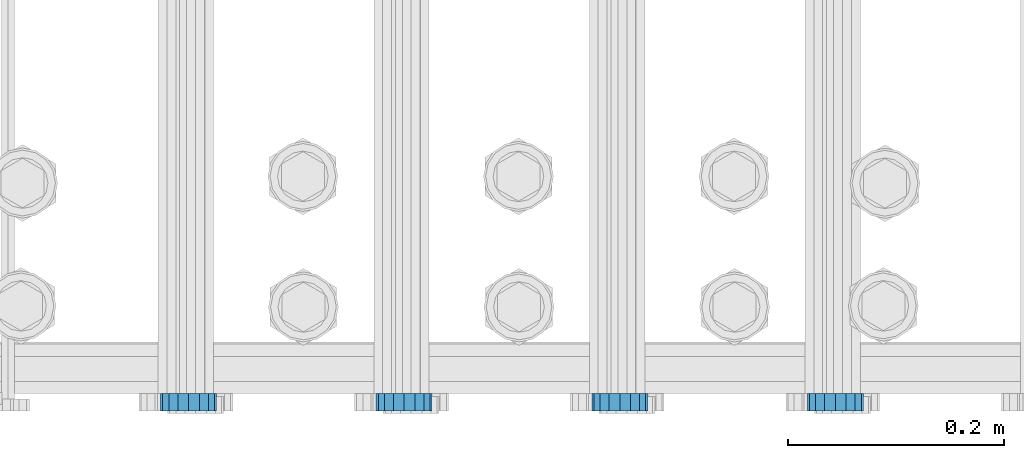
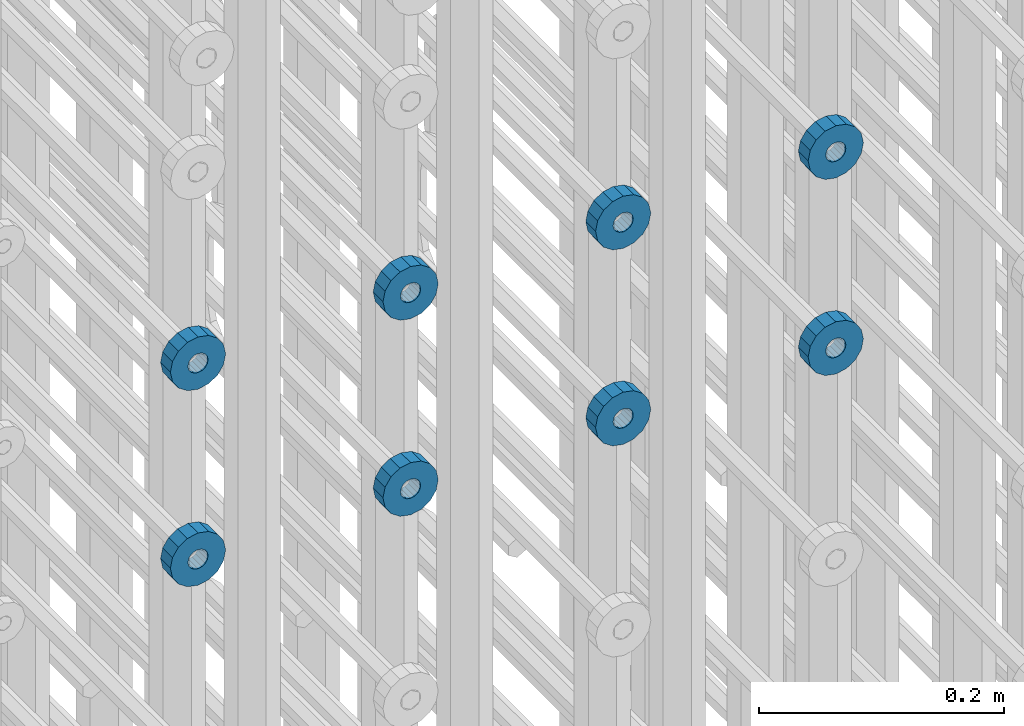
# One storey, part 131 of 177: 8 beams.
"""IFC2X3 building model written with IfcOpenShell, lengths in millimetres."""

from ifc_helpers import new_model, si_unit, frame, origin_with_axes, place, context, subcontext, project, spatial, faceted_brep, material, type_object, element, save


model = new_model("IFC2X3")

# Units and contexts
model_context_1 = context("Model", 3, precision=1e-05, world=origin_with_axes())
model_context_2 = context("Model", 3, precision=1e-05, world=origin_with_axes())
body_context = subcontext(model_context_2, "Body", "Model", "MODEL_VIEW")
ifc_project = project(units=[si_unit("LENGTHUNIT", "METRE", prefix="MILLI"), si_unit("AREAUNIT", "SQUARE_METRE"), si_unit("VOLUMEUNIT", "CUBIC_METRE"), si_unit("MASSUNIT", "GRAM", prefix="KILO"), si_unit("TIMEUNIT", "SECOND"), si_unit("PLANEANGLEUNIT", "RADIAN"), si_unit("SOLIDANGLEUNIT", "STERADIAN"), si_unit("THERMODYNAMICTEMPERATUREUNIT", "DEGREE_CELSIUS"), si_unit("LUMINOUSINTENSITYUNIT", "LUMEN")], contexts=[model_context_1])

# Site, building, storey
site_placement = place(None, origin_with_axes())
site = spatial("IfcSite", under=ifc_project, at=site_placement, CompositionType="ELEMENT")
building_placement = place(site_placement, origin_with_axes())
building = spatial("IfcBuilding", under=site, at=building_placement, Name="Undefined", CompositionType="ELEMENT")
storey_placement = place(building_placement, origin_with_axes())
storey = spatial("IfcBuildingStorey", under=building, at=storey_placement, Name="Undefined", CompositionType="ELEMENT", Elevation=0.0)

# Beams
ifc_material = material(Name="STEEL/Steel_Undefined")
beam_type = type_object("IfcBeamType", PredefinedType="NOTDEFINED")
beam_1_placement = place(storey_placement, frame((2032729.49847313, 6205075.98588032, 21954.9868114201), z_axis=(0.0, 0.0, -1.0), x_axis=(0.0, -1.0, 0.0)))
element("IfcBeam", 1, at=beam_1_placement, inside=storey, type_object=beam_type, material=ifc_material, context=body_context, shape_type="Brep", body=[
    faceted_brep([(0.0, -9.5, 0.0), (0.0, -8.77685555908829, 3.63549260746731), (16.0, -8.77685555908829, 3.63549260746731), (16.0, -9.5, 0.0), (0.0, -6.71751442085952, 6.71751442127061), (16.0, -6.71751442085952, 6.71751442127061), (0.0, -3.63549260701984, 8.77685555885546), (16.0, -3.63549260701984, 8.77685555885546), (-2.02452244836415e-12, 0.0, 9.5), (16.0, 0.0, 9.5), (0.0, 3.63549260701984, 8.77685555885546), (16.0, 3.63549260701984, 8.77685555885546), (0.0, 6.71751442085952, 6.71751442127061), (16.0, 6.71751442085952, 6.71751442127061), (0.0, 8.77685555908829, 3.63549260746731), (16.0, 8.77685555908829, 3.63549260746731), (0.0, 9.5, 0.0), (16.0, 9.5, 0.0), (0.0, 8.77685555908829, -3.63549260746731), (16.0, 8.77685555908829, -3.63549260746731), (0.0, 6.71751442085952, -6.71751442127061), (16.0, 6.71751442085952, -6.71751442127061), (0.0, 3.63549260701984, -8.77685555885546), (16.0, 3.63549260701984, -8.77685555885546), (2.02452244836415e-12, -3.69149155687865e-15, -9.5), (16.0, 0.0, -9.5), (0.0, -3.63549260701984, -8.77685555885546), (16.0, -3.63549260701984, -8.77685555885546), (0.0, -6.71751442085952, -6.71751442127061), (16.0, -6.71751442085952, -6.71751442127061), (0.0, -8.77685555908829, -3.63549260746731), (16.0, -8.77685555908829, -3.63549260746731), (0.0, -26.0, 0.0), (0.0, -24.0208678450435, -9.94976924149159), (16.0, -24.0208678450435, -9.94976924149159), (16.0, -26.0, 0.0), (0.0, -18.3847763109952, -18.3847763108497), (16.0, -18.3847763109952, -18.3847763108497), (0.0, -9.94976924173534, -24.0208678452946), (16.0, -9.94976924173534, -24.0208678452946), (0.0, 0.0, -26.0), (16.0, 0.0, -26.0), (0.0, 9.94976924173534, -24.0208678452946), (16.0, 9.94976924173534, -24.0208678452946), (0.0, 18.3847763109952, -18.3847763108497), (16.0, 18.3847763109952, -18.3847763108497), (0.0, 24.0208678450435, -9.94976924149159), (16.0, 24.0208678450435, -9.94976924149159), (0.0, 26.0, 0.0), (16.0, 26.0, 0.0), (0.0, 24.0208678450435, 9.94976924149159), (16.0, 24.0208678450435, 9.94976924149159), (0.0, 18.3847763109952, 18.3847763108497), (16.0, 18.3847763109952, 18.3847763108497), (0.0, 9.94976924173534, 24.0208678452946), (16.0, 9.94976924173534, 24.0208678452946), (0.0, 0.0, 26.0), (16.0, 0.0, 26.0), (0.0, -9.94976924173534, 24.0208678452946), (16.0, -9.94976924173534, 24.0208678452946), (0.0, -18.3847763109952, 18.3847763108497), (16.0, -18.3847763109952, 18.3847763108497), (0.0, -24.0208678450435, 9.94976924149159), (16.0, -24.0208678450435, 9.94976924149159)], [[[0, 1, 2, 3]], [[1, 4, 5, 2]], [[4, 6, 7, 5]], [[6, 8, 9, 7]], [[8, 10, 11, 9]], [[10, 12, 13, 11]], [[12, 14, 15, 13]], [[14, 16, 17, 15]], [[16, 18, 19, 17]], [[18, 20, 21, 19]], [[20, 22, 23, 21]], [[22, 24, 25, 23]], [[24, 26, 27, 25]], [[26, 28, 29, 27]], [[28, 30, 31, 29]], [[30, 0, 3, 31]], [[32, 33, 34, 35]], [[33, 36, 37, 34]], [[36, 38, 39, 37]], [[38, 40, 41, 39]], [[40, 42, 43, 41]], [[42, 44, 45, 43]], [[44, 46, 47, 45]], [[46, 48, 49, 47]], [[48, 50, 51, 49]], [[50, 52, 53, 51]], [[52, 54, 55, 53]], [[54, 56, 57, 55]], [[56, 58, 59, 57]], [[58, 60, 61, 59]], [[60, 62, 63, 61]], [[62, 32, 35, 63]], [[37, 39, 41, 43, 45, 47, 49, 51, 53, 55, 57, 59, 61, 63, 35, 34], [5, 7, 9, 11, 13, 15, 17, 19, 21, 23, 25, 27, 29, 31, 3, 2]], [[62, 60, 58, 56, 54, 52, 50, 48, 46, 44, 42, 40, 38, 36, 33, 32], [30, 28, 26, 24, 22, 20, 18, 16, 14, 12, 10, 8, 6, 4, 1, 0]]]),
])
beam_2_placement = place(storey_placement, frame((2032529.49847313, 6205075.98588032, 21954.9868114201), z_axis=(0.0, 0.0, -1.0), x_axis=(0.0, -1.0, 0.0)))
element("IfcBeam", 2, at=beam_2_placement, inside=storey, type_object=beam_type, material=ifc_material, context=body_context, shape_type="Brep", body=[
    faceted_brep([(0.0, -9.5, 0.0), (0.0, -8.77685555908829, 3.63549260746731), (16.0, -8.77685555908829, 3.63549260746731), (16.0, -9.5, 0.0), (0.0, -6.71751442085952, 6.71751442127061), (16.0, -6.71751442085952, 6.71751442127061), (0.0, -3.63549260701984, 8.77685555885546), (16.0, -3.63549260701984, 8.77685555885546), (-2.02452244836415e-12, 0.0, 9.5), (16.0, 0.0, 9.5), (0.0, 3.63549260701984, 8.77685555885546), (16.0, 3.63549260701984, 8.77685555885546), (0.0, 6.71751442085952, 6.71751442127061), (16.0, 6.71751442085952, 6.71751442127061), (0.0, 8.77685555908829, 3.63549260746731), (16.0, 8.77685555908829, 3.63549260746731), (0.0, 9.5, 0.0), (16.0, 9.5, 0.0), (0.0, 8.77685555908829, -3.63549260746731), (16.0, 8.77685555908829, -3.63549260746731), (0.0, 6.71751442085952, -6.71751442127061), (16.0, 6.71751442085952, -6.71751442127061), (0.0, 3.63549260701984, -8.77685555885546), (16.0, 3.63549260701984, -8.77685555885546), (2.02452244836415e-12, -3.69149155687865e-15, -9.5), (16.0, 0.0, -9.5), (0.0, -3.63549260701984, -8.77685555885546), (16.0, -3.63549260701984, -8.77685555885546), (0.0, -6.71751442085952, -6.71751442127061), (16.0, -6.71751442085952, -6.71751442127061), (0.0, -8.77685555908829, -3.63549260746731), (16.0, -8.77685555908829, -3.63549260746731), (0.0, -26.0, 0.0), (0.0, -24.0208678450435, -9.94976924149159), (16.0, -24.0208678450435, -9.94976924149159), (16.0, -26.0, 0.0), (0.0, -18.3847763109952, -18.3847763108497), (16.0, -18.3847763109952, -18.3847763108497), (0.0, -9.94976924173534, -24.0208678452946), (16.0, -9.94976924173534, -24.0208678452946), (0.0, 0.0, -26.0), (16.0, 0.0, -26.0), (0.0, 9.94976924173534, -24.0208678452946), (16.0, 9.94976924173534, -24.0208678452946), (0.0, 18.3847763109952, -18.3847763108497), (16.0, 18.3847763109952, -18.3847763108497), (0.0, 24.0208678450435, -9.94976924149159), (16.0, 24.0208678450435, -9.94976924149159), (0.0, 26.0, 0.0), (16.0, 26.0, 0.0), (0.0, 24.0208678450435, 9.94976924149159), (16.0, 24.0208678450435, 9.94976924149159), (0.0, 18.3847763109952, 18.3847763108497), (16.0, 18.3847763109952, 18.3847763108497), (0.0, 9.94976924173534, 24.0208678452946), (16.0, 9.94976924173534, 24.0208678452946), (0.0, 0.0, 26.0), (16.0, 0.0, 26.0), (0.0, -9.94976924173534, 24.0208678452946), (16.0, -9.94976924173534, 24.0208678452946), (0.0, -18.3847763109952, 18.3847763108497), (16.0, -18.3847763109952, 18.3847763108497), (0.0, -24.0208678450435, 9.94976924149159), (16.0, -24.0208678450435, 9.94976924149159)], [[[0, 1, 2, 3]], [[1, 4, 5, 2]], [[4, 6, 7, 5]], [[6, 8, 9, 7]], [[8, 10, 11, 9]], [[10, 12, 13, 11]], [[12, 14, 15, 13]], [[14, 16, 17, 15]], [[16, 18, 19, 17]], [[18, 20, 21, 19]], [[20, 22, 23, 21]], [[22, 24, 25, 23]], [[24, 26, 27, 25]], [[26, 28, 29, 27]], [[28, 30, 31, 29]], [[30, 0, 3, 31]], [[32, 33, 34, 35]], [[33, 36, 37, 34]], [[36, 38, 39, 37]], [[38, 40, 41, 39]], [[40, 42, 43, 41]], [[42, 44, 45, 43]], [[44, 46, 47, 45]], [[46, 48, 49, 47]], [[48, 50, 51, 49]], [[50, 52, 53, 51]], [[52, 54, 55, 53]], [[54, 56, 57, 55]], [[56, 58, 59, 57]], [[58, 60, 61, 59]], [[60, 62, 63, 61]], [[62, 32, 35, 63]], [[37, 39, 41, 43, 45, 47, 49, 51, 53, 55, 57, 59, 61, 63, 35, 34], [5, 7, 9, 11, 13, 15, 17, 19, 21, 23, 25, 27, 29, 31, 3, 2]], [[62, 60, 58, 56, 54, 52, 50, 48, 46, 44, 42, 40, 38, 36, 33, 32], [30, 28, 26, 24, 22, 20, 18, 16, 14, 12, 10, 8, 6, 4, 1, 0]]]),
])
beam_3_placement = place(storey_placement, frame((2032329.49847313, 6205075.98588032, 21954.9868114201), z_axis=(0.0, 0.0, -1.0), x_axis=(0.0, -1.0, 0.0)))
element("IfcBeam", 3, at=beam_3_placement, inside=storey, type_object=beam_type, material=ifc_material, context=body_context, shape_type="Brep", body=[
    faceted_brep([(0.0, -9.5, 0.0), (0.0, -8.77685555908829, 3.63549260746731), (16.0, -8.77685555908829, 3.63549260746731), (16.0, -9.5, 0.0), (0.0, -6.71751442085952, 6.71751442127061), (16.0, -6.71751442085952, 6.71751442127061), (0.0, -3.63549260701984, 8.77685555885546), (16.0, -3.63549260701984, 8.77685555885546), (-2.02452244836415e-12, 0.0, 9.5), (16.0, 0.0, 9.5), (0.0, 3.63549260701984, 8.77685555885546), (16.0, 3.63549260701984, 8.77685555885546), (0.0, 6.71751442085952, 6.71751442127061), (16.0, 6.71751442085952, 6.71751442127061), (0.0, 8.77685555908829, 3.63549260746731), (16.0, 8.77685555908829, 3.63549260746731), (0.0, 9.5, 0.0), (16.0, 9.5, 0.0), (0.0, 8.77685555908829, -3.63549260746731), (16.0, 8.77685555908829, -3.63549260746731), (0.0, 6.71751442085952, -6.71751442127061), (16.0, 6.71751442085952, -6.71751442127061), (0.0, 3.63549260701984, -8.77685555885546), (16.0, 3.63549260701984, -8.77685555885546), (2.02452244836415e-12, -3.69149155687865e-15, -9.5), (16.0, 0.0, -9.5), (0.0, -3.63549260701984, -8.77685555885546), (16.0, -3.63549260701984, -8.77685555885546), (0.0, -6.71751442085952, -6.71751442127061), (16.0, -6.71751442085952, -6.71751442127061), (0.0, -8.77685555908829, -3.63549260746731), (16.0, -8.77685555908829, -3.63549260746731), (0.0, -26.0, 0.0), (0.0, -24.0208678450435, -9.94976924149159), (16.0, -24.0208678450435, -9.94976924149159), (16.0, -26.0, 0.0), (0.0, -18.3847763109952, -18.3847763108497), (16.0, -18.3847763109952, -18.3847763108497), (0.0, -9.94976924173534, -24.0208678452946), (16.0, -9.94976924173534, -24.0208678452946), (0.0, 0.0, -26.0), (16.0, 0.0, -26.0), (0.0, 9.94976924173534, -24.0208678452946), (16.0, 9.94976924173534, -24.0208678452946), (0.0, 18.3847763109952, -18.3847763108497), (16.0, 18.3847763109952, -18.3847763108497), (0.0, 24.0208678450435, -9.94976924149159), (16.0, 24.0208678450435, -9.94976924149159), (0.0, 26.0, 0.0), (16.0, 26.0, 0.0), (0.0, 24.0208678450435, 9.94976924149159), (16.0, 24.0208678450435, 9.94976924149159), (0.0, 18.3847763109952, 18.3847763108497), (16.0, 18.3847763109952, 18.3847763108497), (0.0, 9.94976924173534, 24.0208678452946), (16.0, 9.94976924173534, 24.0208678452946), (0.0, 0.0, 26.0), (16.0, 0.0, 26.0), (0.0, -9.94976924173534, 24.0208678452946), (16.0, -9.94976924173534, 24.0208678452946), (0.0, -18.3847763109952, 18.3847763108497), (16.0, -18.3847763109952, 18.3847763108497), (0.0, -24.0208678450435, 9.94976924149159), (16.0, -24.0208678450435, 9.94976924149159)], [[[0, 1, 2, 3]], [[1, 4, 5, 2]], [[4, 6, 7, 5]], [[6, 8, 9, 7]], [[8, 10, 11, 9]], [[10, 12, 13, 11]], [[12, 14, 15, 13]], [[14, 16, 17, 15]], [[16, 18, 19, 17]], [[18, 20, 21, 19]], [[20, 22, 23, 21]], [[22, 24, 25, 23]], [[24, 26, 27, 25]], [[26, 28, 29, 27]], [[28, 30, 31, 29]], [[30, 0, 3, 31]], [[32, 33, 34, 35]], [[33, 36, 37, 34]], [[36, 38, 39, 37]], [[38, 40, 41, 39]], [[40, 42, 43, 41]], [[42, 44, 45, 43]], [[44, 46, 47, 45]], [[46, 48, 49, 47]], [[48, 50, 51, 49]], [[50, 52, 53, 51]], [[52, 54, 55, 53]], [[54, 56, 57, 55]], [[56, 58, 59, 57]], [[58, 60, 61, 59]], [[60, 62, 63, 61]], [[62, 32, 35, 63]], [[37, 39, 41, 43, 45, 47, 49, 51, 53, 55, 57, 59, 61, 63, 35, 34], [5, 7, 9, 11, 13, 15, 17, 19, 21, 23, 25, 27, 29, 31, 3, 2]], [[62, 60, 58, 56, 54, 52, 50, 48, 46, 44, 42, 40, 38, 36, 33, 32], [30, 28, 26, 24, 22, 20, 18, 16, 14, 12, 10, 8, 6, 4, 1, 0]]]),
])
beam_4_placement = place(storey_placement, frame((2032129.49847313, 6205075.98588032, 21954.9868114201), z_axis=(0.0, 0.0, -1.0), x_axis=(0.0, -1.0, 0.0)))
element("IfcBeam", 4, at=beam_4_placement, inside=storey, type_object=beam_type, material=ifc_material, context=body_context, shape_type="Brep", body=[
    faceted_brep([(0.0, -9.5, 0.0), (0.0, -8.77685555908829, 3.63549260746731), (16.0, -8.77685555908829, 3.63549260746731), (16.0, -9.5, 0.0), (0.0, -6.71751442085952, 6.71751442127061), (16.0, -6.71751442085952, 6.71751442127061), (0.0, -3.63549260701984, 8.77685555885546), (16.0, -3.63549260701984, 8.77685555885546), (-2.02452244836415e-12, 0.0, 9.5), (16.0, 0.0, 9.5), (0.0, 3.63549260701984, 8.77685555885546), (16.0, 3.63549260701984, 8.77685555885546), (0.0, 6.71751442085952, 6.71751442127061), (16.0, 6.71751442085952, 6.71751442127061), (0.0, 8.77685555908829, 3.63549260746731), (16.0, 8.77685555908829, 3.63549260746731), (0.0, 9.5, 0.0), (16.0, 9.5, 0.0), (0.0, 8.77685555908829, -3.63549260746731), (16.0, 8.77685555908829, -3.63549260746731), (0.0, 6.71751442085952, -6.71751442127061), (16.0, 6.71751442085952, -6.71751442127061), (0.0, 3.63549260701984, -8.77685555885546), (16.0, 3.63549260701984, -8.77685555885546), (2.02452244836415e-12, -3.69149155687865e-15, -9.5), (16.0, 0.0, -9.5), (0.0, -3.63549260701984, -8.77685555885546), (16.0, -3.63549260701984, -8.77685555885546), (0.0, -6.71751442085952, -6.71751442127061), (16.0, -6.71751442085952, -6.71751442127061), (0.0, -8.77685555908829, -3.63549260746731), (16.0, -8.77685555908829, -3.63549260746731), (0.0, -26.0, 0.0), (0.0, -24.0208678450435, -9.94976924149159), (16.0, -24.0208678450435, -9.94976924149159), (16.0, -26.0, 0.0), (0.0, -18.3847763109952, -18.3847763108497), (16.0, -18.3847763109952, -18.3847763108497), (0.0, -9.94976924173534, -24.0208678452946), (16.0, -9.94976924173534, -24.0208678452946), (0.0, 0.0, -26.0), (16.0, 0.0, -26.0), (0.0, 9.94976924173534, -24.0208678452946), (16.0, 9.94976924173534, -24.0208678452946), (0.0, 18.3847763109952, -18.3847763108497), (16.0, 18.3847763109952, -18.3847763108497), (0.0, 24.0208678450435, -9.94976924149159), (16.0, 24.0208678450435, -9.94976924149159), (0.0, 26.0, 0.0), (16.0, 26.0, 0.0), (0.0, 24.0208678450435, 9.94976924149159), (16.0, 24.0208678450435, 9.94976924149159), (0.0, 18.3847763109952, 18.3847763108497), (16.0, 18.3847763109952, 18.3847763108497), (0.0, 9.94976924173534, 24.0208678452946), (16.0, 9.94976924173534, 24.0208678452946), (0.0, 0.0, 26.0), (16.0, 0.0, 26.0), (0.0, -9.94976924173534, 24.0208678452946), (16.0, -9.94976924173534, 24.0208678452946), (0.0, -18.3847763109952, 18.3847763108497), (16.0, -18.3847763109952, 18.3847763108497), (0.0, -24.0208678450435, 9.94976924149159), (16.0, -24.0208678450435, 9.94976924149159)], [[[0, 1, 2, 3]], [[1, 4, 5, 2]], [[4, 6, 7, 5]], [[6, 8, 9, 7]], [[8, 10, 11, 9]], [[10, 12, 13, 11]], [[12, 14, 15, 13]], [[14, 16, 17, 15]], [[16, 18, 19, 17]], [[18, 20, 21, 19]], [[20, 22, 23, 21]], [[22, 24, 25, 23]], [[24, 26, 27, 25]], [[26, 28, 29, 27]], [[28, 30, 31, 29]], [[30, 0, 3, 31]], [[32, 33, 34, 35]], [[33, 36, 37, 34]], [[36, 38, 39, 37]], [[38, 40, 41, 39]], [[40, 42, 43, 41]], [[42, 44, 45, 43]], [[44, 46, 47, 45]], [[46, 48, 49, 47]], [[48, 50, 51, 49]], [[50, 52, 53, 51]], [[52, 54, 55, 53]], [[54, 56, 57, 55]], [[56, 58, 59, 57]], [[58, 60, 61, 59]], [[60, 62, 63, 61]], [[62, 32, 35, 63]], [[37, 39, 41, 43, 45, 47, 49, 51, 53, 55, 57, 59, 61, 63, 35, 34], [5, 7, 9, 11, 13, 15, 17, 19, 21, 23, 25, 27, 29, 31, 3, 2]], [[62, 60, 58, 56, 54, 52, 50, 48, 46, 44, 42, 40, 38, 36, 33, 32], [30, 28, 26, 24, 22, 20, 18, 16, 14, 12, 10, 8, 6, 4, 1, 0]]]),
])
beam_5_placement = place(storey_placement, frame((2032729.49847313, 6205075.98588607, 21759.986812672), z_axis=(0.0, 0.0, -1.0), x_axis=(0.0, -1.0, 0.0)))
element("IfcBeam", 5, at=beam_5_placement, inside=storey, type_object=beam_type, material=ifc_material, context=body_context, shape_type="Brep", body=[
    faceted_brep([(0.0, -9.5, 0.0), (0.0, -8.77685555908829, 3.63549260746731), (16.0, -8.77685555908829, 3.63549260746731), (16.0, -9.5, 0.0), (0.0, -6.71751442085952, 6.71751442127061), (16.0, -6.71751442085952, 6.71751442127061), (0.0, -3.63549260701984, 8.77685555885546), (16.0, -3.63549260701984, 8.77685555885546), (-2.02452244836415e-12, 0.0, 9.5), (16.0, 0.0, 9.5), (0.0, 3.63549260701984, 8.77685555885546), (16.0, 3.63549260701984, 8.77685555885546), (0.0, 6.71751442085952, 6.71751442127061), (16.0, 6.71751442085952, 6.71751442127061), (0.0, 8.77685555908829, 3.63549260746731), (16.0, 8.77685555908829, 3.63549260746731), (0.0, 9.5, 0.0), (16.0, 9.5, 0.0), (0.0, 8.77685555908829, -3.63549260746731), (16.0, 8.77685555908829, -3.63549260746731), (0.0, 6.71751442085952, -6.71751442127061), (16.0, 6.71751442085952, -6.71751442127061), (0.0, 3.63549260701984, -8.77685555885546), (16.0, 3.63549260701984, -8.77685555885546), (2.02452244836415e-12, -3.69149155687865e-15, -9.5), (16.0, 0.0, -9.5), (0.0, -3.63549260701984, -8.77685555885546), (16.0, -3.63549260701984, -8.77685555885546), (0.0, -6.71751442085952, -6.71751442127061), (16.0, -6.71751442085952, -6.71751442127061), (0.0, -8.77685555908829, -3.63549260746731), (16.0, -8.77685555908829, -3.63549260746731), (0.0, -26.0, 0.0), (0.0, -24.0208678450435, -9.94976924149159), (16.0, -24.0208678450435, -9.94976924149159), (16.0, -26.0, 0.0), (0.0, -18.3847763109952, -18.3847763108497), (16.0, -18.3847763109952, -18.3847763108497), (0.0, -9.94976924173534, -24.0208678452946), (16.0, -9.94976924173534, -24.0208678452946), (0.0, 0.0, -26.0), (16.0, 0.0, -26.0), (0.0, 9.94976924173534, -24.0208678452946), (16.0, 9.94976924173534, -24.0208678452946), (0.0, 18.3847763109952, -18.3847763108497), (16.0, 18.3847763109952, -18.3847763108497), (0.0, 24.0208678450435, -9.94976924149159), (16.0, 24.0208678450435, -9.94976924149159), (0.0, 26.0, 0.0), (16.0, 26.0, 0.0), (0.0, 24.0208678450435, 9.94976924149159), (16.0, 24.0208678450435, 9.94976924149159), (0.0, 18.3847763109952, 18.3847763108497), (16.0, 18.3847763109952, 18.3847763108497), (0.0, 9.94976924173534, 24.0208678452946), (16.0, 9.94976924173534, 24.0208678452946), (0.0, 0.0, 26.0), (16.0, 0.0, 26.0), (0.0, -9.94976924173534, 24.0208678452946), (16.0, -9.94976924173534, 24.0208678452946), (0.0, -18.3847763109952, 18.3847763108497), (16.0, -18.3847763109952, 18.3847763108497), (0.0, -24.0208678450435, 9.94976924149159), (16.0, -24.0208678450435, 9.94976924149159)], [[[0, 1, 2, 3]], [[1, 4, 5, 2]], [[4, 6, 7, 5]], [[6, 8, 9, 7]], [[8, 10, 11, 9]], [[10, 12, 13, 11]], [[12, 14, 15, 13]], [[14, 16, 17, 15]], [[16, 18, 19, 17]], [[18, 20, 21, 19]], [[20, 22, 23, 21]], [[22, 24, 25, 23]], [[24, 26, 27, 25]], [[26, 28, 29, 27]], [[28, 30, 31, 29]], [[30, 0, 3, 31]], [[32, 33, 34, 35]], [[33, 36, 37, 34]], [[36, 38, 39, 37]], [[38, 40, 41, 39]], [[40, 42, 43, 41]], [[42, 44, 45, 43]], [[44, 46, 47, 45]], [[46, 48, 49, 47]], [[48, 50, 51, 49]], [[50, 52, 53, 51]], [[52, 54, 55, 53]], [[54, 56, 57, 55]], [[56, 58, 59, 57]], [[58, 60, 61, 59]], [[60, 62, 63, 61]], [[62, 32, 35, 63]], [[37, 39, 41, 43, 45, 47, 49, 51, 53, 55, 57, 59, 61, 63, 35, 34], [5, 7, 9, 11, 13, 15, 17, 19, 21, 23, 25, 27, 29, 31, 3, 2]], [[62, 60, 58, 56, 54, 52, 50, 48, 46, 44, 42, 40, 38, 36, 33, 32], [30, 28, 26, 24, 22, 20, 18, 16, 14, 12, 10, 8, 6, 4, 1, 0]]]),
])
beam_6_placement = place(storey_placement, frame((2032529.49847313, 6205075.98588607, 21759.986812672), z_axis=(0.0, 0.0, -1.0), x_axis=(0.0, -1.0, 0.0)))
element("IfcBeam", 6, at=beam_6_placement, inside=storey, type_object=beam_type, material=ifc_material, context=body_context, shape_type="Brep", body=[
    faceted_brep([(0.0, -9.5, 0.0), (0.0, -8.77685555908829, 3.63549260746731), (16.0, -8.77685555908829, 3.63549260746731), (16.0, -9.5, 0.0), (0.0, -6.71751442085952, 6.71751442127061), (16.0, -6.71751442085952, 6.71751442127061), (0.0, -3.63549260701984, 8.77685555885546), (16.0, -3.63549260701984, 8.77685555885546), (-2.02452244836415e-12, 0.0, 9.5), (16.0, 0.0, 9.5), (0.0, 3.63549260701984, 8.77685555885546), (16.0, 3.63549260701984, 8.77685555885546), (0.0, 6.71751442085952, 6.71751442127061), (16.0, 6.71751442085952, 6.71751442127061), (0.0, 8.77685555908829, 3.63549260746731), (16.0, 8.77685555908829, 3.63549260746731), (0.0, 9.5, 0.0), (16.0, 9.5, 0.0), (0.0, 8.77685555908829, -3.63549260746731), (16.0, 8.77685555908829, -3.63549260746731), (0.0, 6.71751442085952, -6.71751442127061), (16.0, 6.71751442085952, -6.71751442127061), (0.0, 3.63549260701984, -8.77685555885546), (16.0, 3.63549260701984, -8.77685555885546), (2.02452244836415e-12, -3.69149155687865e-15, -9.5), (16.0, 0.0, -9.5), (0.0, -3.63549260701984, -8.77685555885546), (16.0, -3.63549260701984, -8.77685555885546), (0.0, -6.71751442085952, -6.71751442127061), (16.0, -6.71751442085952, -6.71751442127061), (0.0, -8.77685555908829, -3.63549260746731), (16.0, -8.77685555908829, -3.63549260746731), (0.0, -26.0, 0.0), (0.0, -24.0208678450435, -9.94976924149159), (16.0, -24.0208678450435, -9.94976924149159), (16.0, -26.0, 0.0), (0.0, -18.3847763109952, -18.3847763108497), (16.0, -18.3847763109952, -18.3847763108497), (0.0, -9.94976924173534, -24.0208678452946), (16.0, -9.94976924173534, -24.0208678452946), (0.0, 0.0, -26.0), (16.0, 0.0, -26.0), (0.0, 9.94976924173534, -24.0208678452946), (16.0, 9.94976924173534, -24.0208678452946), (0.0, 18.3847763109952, -18.3847763108497), (16.0, 18.3847763109952, -18.3847763108497), (0.0, 24.0208678450435, -9.94976924149159), (16.0, 24.0208678450435, -9.94976924149159), (0.0, 26.0, 0.0), (16.0, 26.0, 0.0), (0.0, 24.0208678450435, 9.94976924149159), (16.0, 24.0208678450435, 9.94976924149159), (0.0, 18.3847763109952, 18.3847763108497), (16.0, 18.3847763109952, 18.3847763108497), (0.0, 9.94976924173534, 24.0208678452946), (16.0, 9.94976924173534, 24.0208678452946), (0.0, 0.0, 26.0), (16.0, 0.0, 26.0), (0.0, -9.94976924173534, 24.0208678452946), (16.0, -9.94976924173534, 24.0208678452946), (0.0, -18.3847763109952, 18.3847763108497), (16.0, -18.3847763109952, 18.3847763108497), (0.0, -24.0208678450435, 9.94976924149159), (16.0, -24.0208678450435, 9.94976924149159)], [[[0, 1, 2, 3]], [[1, 4, 5, 2]], [[4, 6, 7, 5]], [[6, 8, 9, 7]], [[8, 10, 11, 9]], [[10, 12, 13, 11]], [[12, 14, 15, 13]], [[14, 16, 17, 15]], [[16, 18, 19, 17]], [[18, 20, 21, 19]], [[20, 22, 23, 21]], [[22, 24, 25, 23]], [[24, 26, 27, 25]], [[26, 28, 29, 27]], [[28, 30, 31, 29]], [[30, 0, 3, 31]], [[32, 33, 34, 35]], [[33, 36, 37, 34]], [[36, 38, 39, 37]], [[38, 40, 41, 39]], [[40, 42, 43, 41]], [[42, 44, 45, 43]], [[44, 46, 47, 45]], [[46, 48, 49, 47]], [[48, 50, 51, 49]], [[50, 52, 53, 51]], [[52, 54, 55, 53]], [[54, 56, 57, 55]], [[56, 58, 59, 57]], [[58, 60, 61, 59]], [[60, 62, 63, 61]], [[62, 32, 35, 63]], [[37, 39, 41, 43, 45, 47, 49, 51, 53, 55, 57, 59, 61, 63, 35, 34], [5, 7, 9, 11, 13, 15, 17, 19, 21, 23, 25, 27, 29, 31, 3, 2]], [[62, 60, 58, 56, 54, 52, 50, 48, 46, 44, 42, 40, 38, 36, 33, 32], [30, 28, 26, 24, 22, 20, 18, 16, 14, 12, 10, 8, 6, 4, 1, 0]]]),
])
beam_7_placement = place(storey_placement, frame((2032329.49847313, 6205075.98588607, 21759.986812672), z_axis=(0.0, 0.0, -1.0), x_axis=(0.0, -1.0, 0.0)))
element("IfcBeam", 7, at=beam_7_placement, inside=storey, type_object=beam_type, material=ifc_material, context=body_context, shape_type="Brep", body=[
    faceted_brep([(0.0, -9.5, 0.0), (0.0, -8.77685555908829, 3.63549260746731), (16.0, -8.77685555908829, 3.63549260746731), (16.0, -9.5, 0.0), (0.0, -6.71751442085952, 6.71751442127061), (16.0, -6.71751442085952, 6.71751442127061), (0.0, -3.63549260701984, 8.77685555885546), (16.0, -3.63549260701984, 8.77685555885546), (-2.02452244836415e-12, 0.0, 9.5), (16.0, 0.0, 9.5), (0.0, 3.63549260701984, 8.77685555885546), (16.0, 3.63549260701984, 8.77685555885546), (0.0, 6.71751442085952, 6.71751442127061), (16.0, 6.71751442085952, 6.71751442127061), (0.0, 8.77685555908829, 3.63549260746731), (16.0, 8.77685555908829, 3.63549260746731), (0.0, 9.5, 0.0), (16.0, 9.5, 0.0), (0.0, 8.77685555908829, -3.63549260746731), (16.0, 8.77685555908829, -3.63549260746731), (0.0, 6.71751442085952, -6.71751442127061), (16.0, 6.71751442085952, -6.71751442127061), (0.0, 3.63549260701984, -8.77685555885546), (16.0, 3.63549260701984, -8.77685555885546), (2.02452244836415e-12, -3.69149155687865e-15, -9.5), (16.0, 0.0, -9.5), (0.0, -3.63549260701984, -8.77685555885546), (16.0, -3.63549260701984, -8.77685555885546), (0.0, -6.71751442085952, -6.71751442127061), (16.0, -6.71751442085952, -6.71751442127061), (0.0, -8.77685555908829, -3.63549260746731), (16.0, -8.77685555908829, -3.63549260746731), (0.0, -26.0, 0.0), (0.0, -24.0208678450435, -9.94976924149159), (16.0, -24.0208678450435, -9.94976924149159), (16.0, -26.0, 0.0), (0.0, -18.3847763109952, -18.3847763108497), (16.0, -18.3847763109952, -18.3847763108497), (0.0, -9.94976924173534, -24.0208678452946), (16.0, -9.94976924173534, -24.0208678452946), (0.0, 0.0, -26.0), (16.0, 0.0, -26.0), (0.0, 9.94976924173534, -24.0208678452946), (16.0, 9.94976924173534, -24.0208678452946), (0.0, 18.3847763109952, -18.3847763108497), (16.0, 18.3847763109952, -18.3847763108497), (0.0, 24.0208678450435, -9.94976924149159), (16.0, 24.0208678450435, -9.94976924149159), (0.0, 26.0, 0.0), (16.0, 26.0, 0.0), (0.0, 24.0208678450435, 9.94976924149159), (16.0, 24.0208678450435, 9.94976924149159), (0.0, 18.3847763109952, 18.3847763108497), (16.0, 18.3847763109952, 18.3847763108497), (0.0, 9.94976924173534, 24.0208678452946), (16.0, 9.94976924173534, 24.0208678452946), (0.0, 0.0, 26.0), (16.0, 0.0, 26.0), (0.0, -9.94976924173534, 24.0208678452946), (16.0, -9.94976924173534, 24.0208678452946), (0.0, -18.3847763109952, 18.3847763108497), (16.0, -18.3847763109952, 18.3847763108497), (0.0, -24.0208678450435, 9.94976924149159), (16.0, -24.0208678450435, 9.94976924149159)], [[[0, 1, 2, 3]], [[1, 4, 5, 2]], [[4, 6, 7, 5]], [[6, 8, 9, 7]], [[8, 10, 11, 9]], [[10, 12, 13, 11]], [[12, 14, 15, 13]], [[14, 16, 17, 15]], [[16, 18, 19, 17]], [[18, 20, 21, 19]], [[20, 22, 23, 21]], [[22, 24, 25, 23]], [[24, 26, 27, 25]], [[26, 28, 29, 27]], [[28, 30, 31, 29]], [[30, 0, 3, 31]], [[32, 33, 34, 35]], [[33, 36, 37, 34]], [[36, 38, 39, 37]], [[38, 40, 41, 39]], [[40, 42, 43, 41]], [[42, 44, 45, 43]], [[44, 46, 47, 45]], [[46, 48, 49, 47]], [[48, 50, 51, 49]], [[50, 52, 53, 51]], [[52, 54, 55, 53]], [[54, 56, 57, 55]], [[56, 58, 59, 57]], [[58, 60, 61, 59]], [[60, 62, 63, 61]], [[62, 32, 35, 63]], [[37, 39, 41, 43, 45, 47, 49, 51, 53, 55, 57, 59, 61, 63, 35, 34], [5, 7, 9, 11, 13, 15, 17, 19, 21, 23, 25, 27, 29, 31, 3, 2]], [[62, 60, 58, 56, 54, 52, 50, 48, 46, 44, 42, 40, 38, 36, 33, 32], [30, 28, 26, 24, 22, 20, 18, 16, 14, 12, 10, 8, 6, 4, 1, 0]]]),
])
beam_8_placement = place(storey_placement, frame((2032129.49847313, 6205075.98588607, 21759.986812672), z_axis=(0.0, 0.0, -1.0), x_axis=(0.0, -1.0, 0.0)))
element("IfcBeam", 8, at=beam_8_placement, inside=storey, type_object=beam_type, material=ifc_material, context=body_context, shape_type="Brep", body=[
    faceted_brep([(0.0, -9.5, 0.0), (0.0, -8.77685555908829, 3.63549260746731), (16.0, -8.77685555908829, 3.63549260746731), (16.0, -9.5, 0.0), (0.0, -6.71751442085952, 6.71751442127061), (16.0, -6.71751442085952, 6.71751442127061), (0.0, -3.63549260701984, 8.77685555885546), (16.0, -3.63549260701984, 8.77685555885546), (-2.02452244836415e-12, 0.0, 9.5), (16.0, 0.0, 9.5), (0.0, 3.63549260701984, 8.77685555885546), (16.0, 3.63549260701984, 8.77685555885546), (0.0, 6.71751442085952, 6.71751442127061), (16.0, 6.71751442085952, 6.71751442127061), (0.0, 8.77685555908829, 3.63549260746731), (16.0, 8.77685555908829, 3.63549260746731), (0.0, 9.5, 0.0), (16.0, 9.5, 0.0), (0.0, 8.77685555908829, -3.63549260746731), (16.0, 8.77685555908829, -3.63549260746731), (0.0, 6.71751442085952, -6.71751442127061), (16.0, 6.71751442085952, -6.71751442127061), (0.0, 3.63549260701984, -8.77685555885546), (16.0, 3.63549260701984, -8.77685555885546), (2.02452244836415e-12, -3.69149155687865e-15, -9.5), (16.0, 0.0, -9.5), (0.0, -3.63549260701984, -8.77685555885546), (16.0, -3.63549260701984, -8.77685555885546), (0.0, -6.71751442085952, -6.71751442127061), (16.0, -6.71751442085952, -6.71751442127061), (0.0, -8.77685555908829, -3.63549260746731), (16.0, -8.77685555908829, -3.63549260746731), (0.0, -26.0, 0.0), (0.0, -24.0208678450435, -9.94976924149159), (16.0, -24.0208678450435, -9.94976924149159), (16.0, -26.0, 0.0), (0.0, -18.3847763109952, -18.3847763108497), (16.0, -18.3847763109952, -18.3847763108497), (0.0, -9.94976924173534, -24.0208678452946), (16.0, -9.94976924173534, -24.0208678452946), (0.0, 0.0, -26.0), (16.0, 0.0, -26.0), (0.0, 9.94976924173534, -24.0208678452946), (16.0, 9.94976924173534, -24.0208678452946), (0.0, 18.3847763109952, -18.3847763108497), (16.0, 18.3847763109952, -18.3847763108497), (0.0, 24.0208678450435, -9.94976924149159), (16.0, 24.0208678450435, -9.94976924149159), (0.0, 26.0, 0.0), (16.0, 26.0, 0.0), (0.0, 24.0208678450435, 9.94976924149159), (16.0, 24.0208678450435, 9.94976924149159), (0.0, 18.3847763109952, 18.3847763108497), (16.0, 18.3847763109952, 18.3847763108497), (0.0, 9.94976924173534, 24.0208678452946), (16.0, 9.94976924173534, 24.0208678452946), (0.0, 0.0, 26.0), (16.0, 0.0, 26.0), (0.0, -9.94976924173534, 24.0208678452946), (16.0, -9.94976924173534, 24.0208678452946), (0.0, -18.3847763109952, 18.3847763108497), (16.0, -18.3847763109952, 18.3847763108497), (0.0, -24.0208678450435, 9.94976924149159), (16.0, -24.0208678450435, 9.94976924149159)], [[[0, 1, 2, 3]], [[1, 4, 5, 2]], [[4, 6, 7, 5]], [[6, 8, 9, 7]], [[8, 10, 11, 9]], [[10, 12, 13, 11]], [[12, 14, 15, 13]], [[14, 16, 17, 15]], [[16, 18, 19, 17]], [[18, 20, 21, 19]], [[20, 22, 23, 21]], [[22, 24, 25, 23]], [[24, 26, 27, 25]], [[26, 28, 29, 27]], [[28, 30, 31, 29]], [[30, 0, 3, 31]], [[32, 33, 34, 35]], [[33, 36, 37, 34]], [[36, 38, 39, 37]], [[38, 40, 41, 39]], [[40, 42, 43, 41]], [[42, 44, 45, 43]], [[44, 46, 47, 45]], [[46, 48, 49, 47]], [[48, 50, 51, 49]], [[50, 52, 53, 51]], [[52, 54, 55, 53]], [[54, 56, 57, 55]], [[56, 58, 59, 57]], [[58, 60, 61, 59]], [[60, 62, 63, 61]], [[62, 32, 35, 63]], [[37, 39, 41, 43, 45, 47, 49, 51, 53, 55, 57, 59, 61, 63, 35, 34], [5, 7, 9, 11, 13, 15, 17, 19, 21, 23, 25, 27, 29, 31, 3, 2]], [[62, 60, 58, 56, 54, 52, 50, 48, 46, 44, 42, 40, 38, 36, 33, 32], [30, 28, 26, 24, 22, 20, 18, 16, 14, 12, 10, 8, 6, 4, 1, 0]]]),
])

save(model, "model.ifc")
